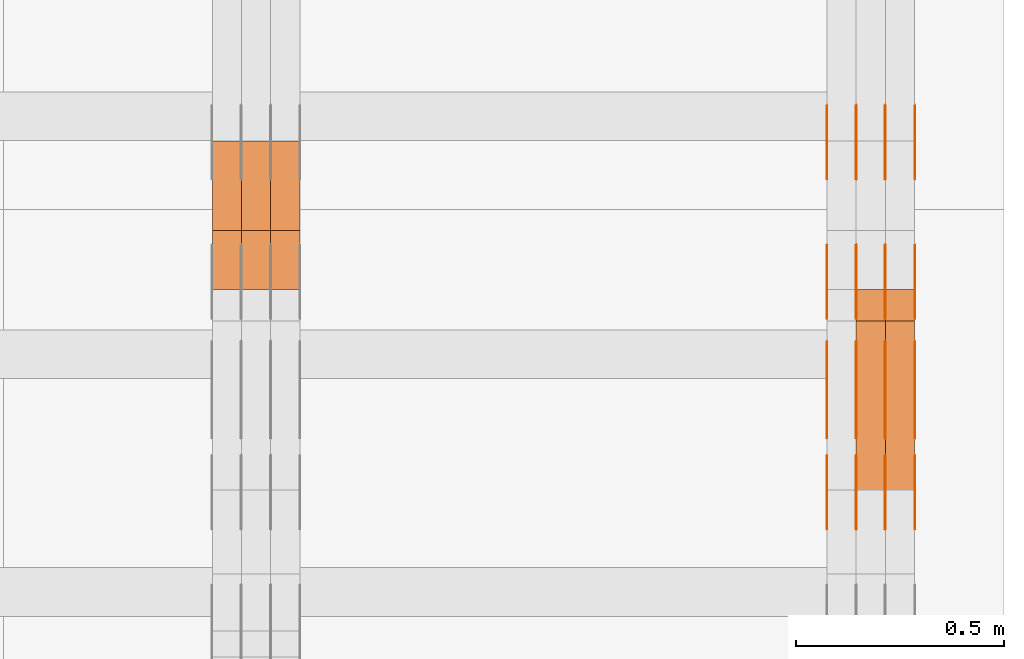
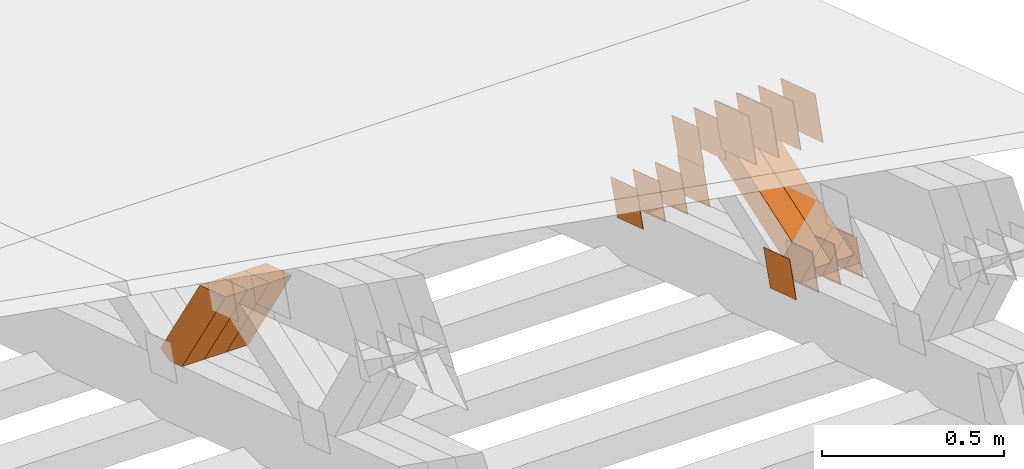
# One storey, part 367 of 385: 29 proxies.
"""IFC2X3 building model written with IfcOpenShell, lengths in millimetres."""

import ifcopenshell
import ifcopenshell.guid

model = None  # the IFC model being written
_history = None  # IfcOwnerHistory: only IFC2X3 demands one
_inside = {}  # id of a spatial element -> (the spatial element, [elements in it])
_under = {}  # id of a project, library or spatial element -> (it, [spatial elements below it])
_declared = {}  # id of a project -> (the project, [libraries it declares])
_typed = {}  # id of a type object -> (the type object, [elements of that type])
_made_of = {}  # id of a material, layer set ... -> (it, [elements and type objects made of it])


def new_model(schema):
    """Start an empty IFC model of exactly this schema.

    Asked for "IFC4X3", IfcOpenShell would pick the latest addendum, in which some entities
    have other attributes; the version numbers below select the first issue.
    IFC2X3 requires an IfcOwnerHistory on every rooted entity: one is made here for all.
    """
    global model, _history
    if schema == "IFC4X3":
        model = ifcopenshell.file(schema_version=(4, 3, 0, 0))
    else:
        model = ifcopenshell.file(schema=schema)
    _inside.clear()
    _under.clear()
    _declared.clear()
    _typed.clear()
    _made_of.clear()
    _history = None
    if model.schema == "IFC2X3":
        org = make("IfcOrganization", Name="unknown")
        user = make(
            "IfcPersonAndOrganization",
            ThePerson=make("IfcPerson", FamilyName="unknown"),
            TheOrganization=org,
        )
        app = make(
            "IfcApplication",
            ApplicationDeveloper=org,
            Version="unknown",
            ApplicationFullName="unknown",
            ApplicationIdentifier="unknown",
        )
        _history = make(
            "IfcOwnerHistory",
            OwningUser=user,
            OwningApplication=app,
            ChangeAction="ADDED",
            CreationDate=0,
        )
    return model


def make(cls, **values):
    """One entity of the class cls with the attributes given. An attribute that is None is left unset."""
    return model.create_entity(
        cls, **{name: value for name, value in values.items() if value is not None}
    )


def entity(cls, *values):
    """Any entity or typed value of the class cls, its attributes in the order of the schema. None: left unset."""
    e = model.create_entity(cls)
    for i, value in enumerate(values):
        if value is not None:
            e[i] = value
    return e


def rooted(cls, **values):
    """An entity with a GlobalId (a new one), such as an element, a storey or a relation."""
    return make(cls, GlobalId=ifcopenshell.guid.new(), OwnerHistory=_history, **values)


def si_unit(unit_type, name, prefix=None):
    """IfcSIUnit, for example si_unit("LENGTHUNIT", "METRE", prefix="MILLI")."""
    return make("IfcSIUnit", UnitType=unit_type, Prefix=prefix, Name=name)


def converted_unit(unit_type, name, factor, base, dimensions=None, offset=None):
    """IfcConversionBasedUnit, such as the inch: factor (a typed value) times the base unit."""
    return make(
        "IfcConversionBasedUnit"
        if offset is None
        else "IfcConversionBasedUnitWithOffset",
        ConversionOffset=offset,
        Dimensions=None
        if dimensions is None
        else entity("IfcDimensionalExponents", *dimensions),
        UnitType=unit_type,
        Name=name,
        ConversionFactor=make(
            "IfcMeasureWithUnit", ValueComponent=factor, UnitComponent=base
        ),
    )


def derived_unit(unit_type, elements):
    """IfcDerivedUnit: a product of units, each with its exponent."""
    return make(
        "IfcDerivedUnit",
        Elements=[
            make("IfcDerivedUnitElement", Unit=unit, Exponent=power)
            for unit, power in elements
        ],
        UnitType=unit_type,
    )


def assignment(units):
    """IfcUnitAssignment: the units of a project."""
    return None if units is None else make("IfcUnitAssignment", Units=units)


def point(xyz):
    """IfcCartesianPoint."""
    return None if xyz is None else make("IfcCartesianPoint", Coordinates=xyz)


def direction(xyz):
    """IfcDirection."""
    return None if xyz is None else make("IfcDirection", DirectionRatios=xyz)


def frame(location, z_axis=None, x_axis=None):
    """IfcAxis2Placement3D, a coordinate frame: its origin and axes. An axis left out is left unset."""
    return make(
        "IfcAxis2Placement3D",
        Location=point(location),
        Axis=direction(z_axis),
        RefDirection=direction(x_axis),
    )


def origin():
    """The frame at (0, 0, 0) with its axes left unset."""
    return frame((0.0, 0.0, 0.0))


def place(relative_to, where):
    """IfcLocalPlacement: puts the frame where relative to a parent placement (None: the world)."""
    return make(
        "IfcLocalPlacement", PlacementRelTo=relative_to, RelativePlacement=where
    )


def context(
    kind, dimensions, precision=None, world=None, true_north=None, identifier=None
):
    """IfcGeometricRepresentationContext, for example the 3D "Model" context."""
    return make(
        "IfcGeometricRepresentationContext",
        ContextIdentifier=identifier,
        ContextType=kind,
        CoordinateSpaceDimension=dimensions,
        Precision=precision,
        WorldCoordinateSystem=world,
        TrueNorth=true_north,
    )


def subcontext(parent, identifier, kind, view, scale=None):
    """IfcGeometricRepresentationSubContext, for example "Body" below "Model"."""
    return make(
        "IfcGeometricRepresentationSubContext",
        ContextIdentifier=identifier,
        ContextType=kind,
        ParentContext=parent,
        TargetScale=scale,
        TargetView=view,
    )


def project(units=None, contexts=None):
    """IfcProject with its units and contexts."""
    return rooted(
        "IfcProject",
        Name="project",
        RepresentationContexts=contexts,
        UnitsInContext=assignment(units),
    )


def spatial(cls, under=None, at=None, **own):
    """A site, building, storey or space (cls), placed at a placement, below another one or the project."""
    s = rooted(cls, ObjectPlacement=at, **own)
    if under is not None:
        _under.setdefault(under.id(), (under, []))[1].append(s)
    return s


def polyline(points):
    """IfcPolyline through the points."""
    return make("IfcPolyline", Points=[point(p) for p in points])


def outline(outer, holes=None, kind="AREA"):
    """IfcArbitraryClosedProfileDef: a profile drawn as a closed curve; with holes, ...WithVoids."""
    if holes is None:
        return make("IfcArbitraryClosedProfileDef", ProfileType=kind, OuterCurve=outer)
    return make(
        "IfcArbitraryProfileDefWithVoids",
        ProfileType=kind,
        OuterCurve=outer,
        InnerCurves=holes,
    )


def extrude(swept, where, along, depth):
    """IfcExtrudedAreaSolid: the profile swept, set in the frame where, extruded along a direction by depth."""
    return make(
        "IfcExtrudedAreaSolid",
        SweptArea=swept,
        Position=where,
        ExtrudedDirection=direction(along),
        Depth=depth,
    )


def shape(context_of_items, identifier, shape_type, items):
    """IfcShapeRepresentation: the items that make up one representation, for example the "Body"."""
    return make(
        "IfcShapeRepresentation",
        ContextOfItems=context_of_items,
        RepresentationIdentifier=identifier,
        RepresentationType=shape_type,
        Items=items,
    )


def source(mapping_origin, context_of_items, identifier, shape_type, items):
    """IfcRepresentationMap: a shape defined once, which mapped items show again and again."""
    return make(
        "IfcRepresentationMap",
        MappingOrigin=mapping_origin,
        MappedRepresentation=shape(context_of_items, identifier, shape_type, items),
    )


def transform(
    local_origin,
    x_axis=None,
    y_axis=None,
    z_axis=None,
    scale=None,
    scale2=None,
    scale3=None,
    uniform=True,
):
    """IfcCartesianTransformationOperator3D, or its non-uniform kind. x_axis, y_axis, z_axis: its Axis1, 2, 3."""
    if uniform:
        return make(
            "IfcCartesianTransformationOperator3D",
            Axis1=direction(x_axis),
            Axis2=direction(y_axis),
            LocalOrigin=point(local_origin),
            Scale=scale,
            Axis3=direction(z_axis),
        )
    return make(
        "IfcCartesianTransformationOperator3DnonUniform",
        Axis1=direction(x_axis),
        Axis2=direction(y_axis),
        LocalOrigin=point(local_origin),
        Scale=scale,
        Axis3=direction(z_axis),
        Scale2=scale2,
        Scale3=scale3,
    )


def mapped(mapping_source, mapping_target):
    """IfcMappedItem: shows the shape of a source again, moved by a transform."""
    return make(
        "IfcMappedItem", MappingSource=mapping_source, MappingTarget=mapping_target
    )


def material(Name=None, Category=None):
    """IfcMaterial."""
    return make("IfcMaterial", Name=Name, Category=Category)


def made_of(thing, what):
    """Note that an element or type object is made of a material, layer set ...; save() writes the relation."""
    if what is not None:
        _made_of.setdefault(what.id(), (what, []))[1].append(thing)
    return thing


def type_object(cls, material=None, **own):
    """A type object (cls), such as IfcWallType, which elements share."""
    return made_of(rooted(cls, **own), material)


def type_shapes(of_type, sources):
    """Give a type object the sources (RepresentationMaps) that its elements show as mapped items."""
    of_type.RepresentationMaps = sources


def element(
    cls,
    number,
    at=None,
    inside=None,
    cuts=None,
    type_object=None,
    material=None,
    context=None,
    identifier="Body",
    shape_type=None,
    held_by="IfcProductDefinitionShape",
    body=None,
    shapes=None,
    **own,
):
    """One element of the class cls, such as IfcWall. Its Tag is "e" and its number.

    at: its placement. inside: the storey or other place that contains it. cuts: it is an
    opening in that element (IfcRelVoidsElement). A single representation is given by context,
    identifier, shape_type and body (its items); several are given by shapes. held_by: the class
    of the entity that holds the representations. save() writes the other relations.
    """
    e = rooted(cls, Tag="e%d" % number, ObjectPlacement=at, **own)
    if body is not None:
        shapes = [shape(context, identifier, shape_type, body)]
    if shapes is not None:
        e.Representation = make(held_by, Representations=shapes)
    if inside is not None:
        _inside.setdefault(inside.id(), (inside, []))[1].append(e)
    if cuts is not None:
        rooted(
            "IfcRelVoidsElement", RelatingBuildingElement=cuts, RelatedOpeningElement=e
        )
    if type_object is not None:
        _typed.setdefault(type_object.id(), (type_object, []))[1].append(e)
    return made_of(e, material)


def aggregate(whole, parts):
    """IfcRelAggregates: a whole, such as a stair, and the parts it consists of."""
    return rooted("IfcRelAggregates", RelatingObject=whole, RelatedObjects=parts)


def save(model, path):
    """Write the relations noted so far, then the file.

    IfcRelAggregates (storeys below a building ...), IfcRelContainedInSpatialStructure (elements
    in a storey), IfcRelDefinesByType, IfcRelAssociatesMaterial and IfcRelDeclares: one each for
    every whole, place, type object, material and project.
    """
    for whole, parts in _under.values():
        aggregate(whole, parts)
    for where, things in _inside.values():
        rooted(
            "IfcRelContainedInSpatialStructure",
            RelatedElements=things,
            RelatingStructure=where,
        )
    for kind, things in _typed.values():
        rooted("IfcRelDefinesByType", RelatedObjects=things, RelatingType=kind)
    for what, things in _made_of.values():
        rooted("IfcRelAssociatesMaterial", RelatedObjects=things, RelatingMaterial=what)
    for by, libraries in _declared.values():
        rooted("IfcRelDeclares", RelatingContext=by, RelatedDefinitions=libraries)
    model.write(path)


model = new_model("IFC2X3")

# Units and contexts
model_context = context("Model", 3, precision=0.01, world=origin(), true_north=direction((6.12303176911189e-17, 1.0)))
body_context = subcontext(model_context, "Body", "Model", "MODEL_VIEW")
ifc_project = project(units=[si_unit("LENGTHUNIT", "METRE", prefix="MILLI"), si_unit("AREAUNIT", "SQUARE_METRE"), si_unit("VOLUMEUNIT", "CUBIC_METRE"), converted_unit("PLANEANGLEUNIT", "DEGREE", entity("IfcRatioMeasure", 0.0174532925199433), si_unit("PLANEANGLEUNIT", "RADIAN"), dimensions=[0, 0, 0, 0, 0, 0, 0]), si_unit("MASSUNIT", "GRAM", prefix="KILO"), derived_unit("MASSDENSITYUNIT", [(si_unit("MASSUNIT", "GRAM", prefix="KILO"), 1), (si_unit("LENGTHUNIT", "METRE"), -3)]), si_unit("TIMEUNIT", "SECOND"), si_unit("FREQUENCYUNIT", "HERTZ"), si_unit("THERMODYNAMICTEMPERATUREUNIT", "DEGREE_CELSIUS"), derived_unit("THERMALTRANSMITTANCEUNIT", [(si_unit("MASSUNIT", "GRAM", prefix="KILO"), 1), (si_unit("THERMODYNAMICTEMPERATUREUNIT", "KELVIN"), -1), (si_unit("TIMEUNIT", "SECOND"), -3)]), derived_unit("VOLUMETRICFLOWRATEUNIT", [(si_unit("LENGTHUNIT", "METRE"), 3), (si_unit("TIMEUNIT", "SECOND"), -1)]), si_unit("ELECTRICCURRENTUNIT", "AMPERE"), si_unit("ELECTRICVOLTAGEUNIT", "VOLT"), si_unit("POWERUNIT", "WATT"), si_unit("FORCEUNIT", "NEWTON", prefix="KILO"), si_unit("ILLUMINANCEUNIT", "LUX"), si_unit("LUMINOUSFLUXUNIT", "LUMEN"), si_unit("LUMINOUSINTENSITYUNIT", "CANDELA"), derived_unit("USERDEFINED", [(si_unit("MASSUNIT", "GRAM", prefix="KILO"), -1), (si_unit("LENGTHUNIT", "METRE"), -2), (si_unit("TIMEUNIT", "SECOND"), 3), (si_unit("LUMINOUSFLUXUNIT", "LUMEN"), 1)]), derived_unit("LINEARVELOCITYUNIT", [(si_unit("LENGTHUNIT", "METRE"), 1), (si_unit("TIMEUNIT", "SECOND"), -1)]), si_unit("PRESSUREUNIT", "PASCAL"), derived_unit("USERDEFINED", [(si_unit("LENGTHUNIT", "METRE"), -2), (si_unit("MASSUNIT", "GRAM", prefix="KILO"), 1), (si_unit("TIMEUNIT", "SECOND"), -2)])], contexts=[model_context])

# Site, building, storey
site_placement = place(None, origin())
site = spatial("IfcSite", under=ifc_project, at=site_placement, CompositionType="ELEMENT")
building_placement = place(site_placement, origin())
building = spatial("IfcBuilding", under=site, at=building_placement, CompositionType="ELEMENT")
storey_placement = place(building_placement, origin())
storey = spatial("IfcBuildingStorey", under=building, at=storey_placement, Name="Default", CompositionType="ELEMENT", Elevation=0.0)

# Proxies
ifc_material_1 = material(Name="IfcSurfaceStyle #625402")
building_element_proxy_type_1 = type_object("IfcBuildingElementProxyType", PredefinedType="NOTDEFINED", material=ifc_material_1)
shared_shape_1 = source(origin(), body_context, "Body", "SweptSolid", [
    extrude(outline(polyline([(-74.9998605591059, -59.9999264677526), (74.999875428623, -59.9999264677526), (74.9998605591068, 59.9999264677526), (-74.9998754286239, 59.9999264677526), (-74.9998605591059, -59.9999264677526)])), frame((75.0000889884782, 60.0000460315623, 0.0), z_axis=(0.0, 0.0, 1.0), x_axis=(-1.0, 0.0, 0.0)), (0.0, 0.0, 1.0), 1.3),
])
type_shapes(building_element_proxy_type_1, [shared_shape_1])
proxy_1_placement = place(building_placement, frame((49861.3, 20621.9679769682, 2241.76551219004), z_axis=(-1.0, 0.0, 0.0), x_axis=(0.0, -0.951056516295154, 0.309016994374948)))
element("IfcBuildingElementProxy", 1, at=proxy_1_placement, inside=storey, type_object=building_element_proxy_type_1, material=ifc_material_1, context=body_context, shape_type="MappedRepresentation", body=[
    mapped(shared_shape_1, transform((0.0, 0.0, 0.0), scale=1.0)),
])
ifc_material_2 = material(Name="IfcSurfaceStyle #625345")
building_element_proxy_type_2 = type_object("IfcBuildingElementProxyType", PredefinedType="NOTDEFINED", material=ifc_material_2)
shared_shape_2 = source(origin(), body_context, "Body", "SweptSolid", [
    extrude(outline(polyline([(-74.9998605591059, -59.9999264677526), (74.999875428623, -59.9999264677526), (74.9998605591068, 59.9999264677526), (-74.9998754286239, 59.9999264677526), (-74.9998605591059, -59.9999264677526)])), frame((75.0000889884782, 60.0000460315623, 0.0), z_axis=(0.0, 0.0, 1.0), x_axis=(-1.0, 0.0, 0.0)), (0.0, 0.0, 1.0), 1.3),
])
type_shapes(building_element_proxy_type_2, [shared_shape_2])
proxy_2_placement = place(building_placement, frame((49790.0, 20621.9679769682, 2241.76551219004), z_axis=(-1.0, 0.0, 0.0), x_axis=(0.0, -0.951056516295154, 0.309016994374948)))
element("IfcBuildingElementProxy", 2, at=proxy_2_placement, inside=storey, type_object=building_element_proxy_type_2, material=ifc_material_2, context=body_context, shape_type="MappedRepresentation", body=[
    mapped(shared_shape_2, transform((0.0, 0.0, 0.0), scale=1.0)),
])
ifc_material_3 = material(Name="IfcSurfaceStyle #625288")
building_element_proxy_type_3 = type_object("IfcBuildingElementProxyType", PredefinedType="NOTDEFINED", material=ifc_material_3)
shared_shape_3 = source(origin(), body_context, "Body", "SweptSolid", [
    extrude(outline(polyline([(-74.9998605591059, -59.9999264677526), (74.999875428623, -59.9999264677526), (74.9998605591068, 59.9999264677526), (-74.9998754286239, 59.9999264677526), (-74.9998605591059, -59.9999264677526)])), frame((75.0000889884782, 60.0000460315623, 0.0), z_axis=(0.0, 0.0, 1.0), x_axis=(-1.0, 0.0, 0.0)), (0.0, 0.0, 1.0), 1.3),
])
type_shapes(building_element_proxy_type_3, [shared_shape_3])
proxy_3_placement = place(building_placement, frame((49791.3, 20621.9679769682, 2241.76551219004), z_axis=(-1.0, 0.0, 0.0), x_axis=(0.0, -0.951056516295154, 0.309016994374948)))
element("IfcBuildingElementProxy", 3, at=proxy_3_placement, inside=storey, type_object=building_element_proxy_type_3, material=ifc_material_3, context=body_context, shape_type="MappedRepresentation", body=[
    mapped(shared_shape_3, transform((0.0, 0.0, 0.0), scale=1.0)),
])
ifc_material_4 = material(Name="IfcSurfaceStyle #625231")
building_element_proxy_type_4 = type_object("IfcBuildingElementProxyType", PredefinedType="NOTDEFINED", material=ifc_material_4)
shared_shape_4 = source(origin(), body_context, "Body", "SweptSolid", [
    extrude(outline(polyline([(-74.9998605591059, -59.9999264677526), (74.999875428623, -59.9999264677526), (74.9998605591068, 59.9999264677526), (-74.9998754286239, 59.9999264677526), (-74.9998605591059, -59.9999264677526)])), frame((75.0000889884782, 60.0000460315623, 0.0), z_axis=(0.0, 0.0, 1.0), x_axis=(-1.0, 0.0, 0.0)), (0.0, 0.0, 1.0), 1.29999999999999),
])
type_shapes(building_element_proxy_type_4, [shared_shape_4])
proxy_4_placement = place(building_placement, frame((49720.0, 20621.9679769682, 2241.76551219004), z_axis=(-1.0, 0.0, 0.0), x_axis=(0.0, -0.951056516295154, 0.309016994374948)))
element("IfcBuildingElementProxy", 4, at=proxy_4_placement, inside=storey, type_object=building_element_proxy_type_4, material=ifc_material_4, context=body_context, shape_type="MappedRepresentation", body=[
    mapped(shared_shape_4, transform((0.0, 0.0, 0.0), scale=1.0)),
])
ifc_material_5 = material(Name="IfcSurfaceStyle #625174")
building_element_proxy_type_5 = type_object("IfcBuildingElementProxyType", PredefinedType="NOTDEFINED", material=ifc_material_5)
shared_shape_5 = source(origin(), body_context, "Body", "SweptSolid", [
    extrude(outline(polyline([(-74.9998605591059, -59.9999264677526), (74.999875428623, -59.9999264677526), (74.9998605591068, 59.9999264677526), (-74.9998754286239, 59.9999264677526), (-74.9998605591059, -59.9999264677526)])), frame((75.0000889884782, 60.0000460315623, 0.0), z_axis=(0.0, 0.0, 1.0), x_axis=(-1.0, 0.0, 0.0)), (0.0, 0.0, 1.0), 1.29999999999999),
])
type_shapes(building_element_proxy_type_5, [shared_shape_5])
proxy_5_placement = place(building_placement, frame((49721.3, 20621.9679769682, 2241.76551219004), z_axis=(-1.0, 0.0, 0.0), x_axis=(0.0, -0.951056516295154, 0.309016994374948)))
element("IfcBuildingElementProxy", 5, at=proxy_5_placement, inside=storey, type_object=building_element_proxy_type_5, material=ifc_material_5, context=body_context, shape_type="MappedRepresentation", body=[
    mapped(shared_shape_5, transform((0.0, 0.0, 0.0), scale=1.0)),
])
ifc_material_6 = material(Name="IfcSurfaceStyle #625117")
building_element_proxy_type_6 = type_object("IfcBuildingElementProxyType", PredefinedType="NOTDEFINED", material=ifc_material_6)
shared_shape_6 = source(origin(), body_context, "Body", "SweptSolid", [
    extrude(outline(polyline([(-74.9998605591059, -59.9999264677526), (74.999875428623, -59.9999264677526), (74.9998605591068, 59.9999264677526), (-74.9998754286239, 59.9999264677526), (-74.9998605591059, -59.9999264677526)])), frame((75.0000889884782, 60.0000460315623, 0.0), z_axis=(0.0, 0.0, 1.0), x_axis=(-1.0, 0.0, 0.0)), (0.0, 0.0, 1.0), 1.29999999999999),
])
type_shapes(building_element_proxy_type_6, [shared_shape_6])
proxy_6_placement = place(building_placement, frame((49650.0, 20621.9679769682, 2241.76551219004), z_axis=(-1.0, 0.0, 0.0), x_axis=(0.0, -0.951056516295154, 0.309016994374948)))
element("IfcBuildingElementProxy", 6, at=proxy_6_placement, inside=storey, type_object=building_element_proxy_type_6, material=ifc_material_6, context=body_context, shape_type="MappedRepresentation", body=[
    mapped(shared_shape_6, transform((0.0, 0.0, 0.0), scale=1.0)),
])
ifc_material_7 = material(Name="IfcSurfaceStyle #623692")
building_element_proxy_type_7 = type_object("IfcBuildingElementProxyType", PredefinedType="NOTDEFINED", material=ifc_material_7)
shared_shape_7 = source(origin(), body_context, "Body", "SweptSolid", [
    extrude(outline(polyline([(-100.000260677523, -72.0000050220369), (100.000341220114, -72.0000050220369), (99.9997962944585, 72.0000050220369), (-99.9998768370492, 72.0000050220369), (-100.000260677523, -72.0000050220369)])), frame((100.000341220114, 72.0001826453454, 0.0), z_axis=(0.0, 0.0, 1.0), x_axis=(-1.0, 0.0, 0.0)), (0.0, 0.0, 1.0), 1.3),
])
type_shapes(building_element_proxy_type_7, [shared_shape_7])
proxy_7_placement = place(building_placement, frame((49861.3, 20382.8706354426, 2409.35285895246), z_axis=(-1.0, 0.0, 0.0), x_axis=(0.0, -0.951056516295154, 0.309016994374948)))
element("IfcBuildingElementProxy", 7, at=proxy_7_placement, inside=storey, type_object=building_element_proxy_type_7, material=ifc_material_7, context=body_context, shape_type="MappedRepresentation", body=[
    mapped(shared_shape_7, transform((0.0, 0.0, 0.0), scale=1.0)),
])
ifc_material_8 = material(Name="IfcSurfaceStyle #623635")
building_element_proxy_type_8 = type_object("IfcBuildingElementProxyType", PredefinedType="NOTDEFINED", material=ifc_material_8)
shared_shape_8 = source(origin(), body_context, "Body", "SweptSolid", [
    extrude(outline(polyline([(-100.000260677523, -72.0000050220369), (100.000341220114, -72.0000050220369), (99.9997962944585, 72.0000050220369), (-99.9998768370492, 72.0000050220369), (-100.000260677523, -72.0000050220369)])), frame((100.000341220114, 72.0001826453454, 0.0), z_axis=(0.0, 0.0, 1.0), x_axis=(-1.0, 0.0, 0.0)), (0.0, 0.0, 1.0), 1.3),
])
type_shapes(building_element_proxy_type_8, [shared_shape_8])
proxy_8_placement = place(building_placement, frame((49790.0, 20382.8706354426, 2409.35285895246), z_axis=(-1.0, 0.0, 0.0), x_axis=(0.0, -0.951056516295154, 0.309016994374948)))
element("IfcBuildingElementProxy", 8, at=proxy_8_placement, inside=storey, type_object=building_element_proxy_type_8, material=ifc_material_8, context=body_context, shape_type="MappedRepresentation", body=[
    mapped(shared_shape_8, transform((0.0, 0.0, 0.0), scale=1.0)),
])
ifc_material_9 = material(Name="IfcSurfaceStyle #623578")
building_element_proxy_type_9 = type_object("IfcBuildingElementProxyType", PredefinedType="NOTDEFINED", material=ifc_material_9)
shared_shape_9 = source(origin(), body_context, "Body", "SweptSolid", [
    extrude(outline(polyline([(-100.000260677523, -72.0000050220369), (100.000341220114, -72.0000050220369), (99.9997962944585, 72.0000050220369), (-99.9998768370492, 72.0000050220369), (-100.000260677523, -72.0000050220369)])), frame((100.000341220114, 72.0001826453454, 0.0), z_axis=(0.0, 0.0, 1.0), x_axis=(-1.0, 0.0, 0.0)), (0.0, 0.0, 1.0), 1.3),
])
type_shapes(building_element_proxy_type_9, [shared_shape_9])
proxy_9_placement = place(building_placement, frame((49791.3, 20382.8706354426, 2409.35285895246), z_axis=(-1.0, 0.0, 0.0), x_axis=(0.0, -0.951056516295154, 0.309016994374948)))
element("IfcBuildingElementProxy", 9, at=proxy_9_placement, inside=storey, type_object=building_element_proxy_type_9, material=ifc_material_9, context=body_context, shape_type="MappedRepresentation", body=[
    mapped(shared_shape_9, transform((0.0, 0.0, 0.0), scale=1.0)),
])
ifc_material_10 = material(Name="IfcSurfaceStyle #623521")
building_element_proxy_type_10 = type_object("IfcBuildingElementProxyType", PredefinedType="NOTDEFINED", material=ifc_material_10)
shared_shape_10 = source(origin(), body_context, "Body", "SweptSolid", [
    extrude(outline(polyline([(-100.000260677523, -72.0000050220369), (100.000341220114, -72.0000050220369), (99.9997962944585, 72.0000050220369), (-99.9998768370492, 72.0000050220369), (-100.000260677523, -72.0000050220369)])), frame((100.000341220114, 72.0001826453454, 0.0), z_axis=(0.0, 0.0, 1.0), x_axis=(-1.0, 0.0, 0.0)), (0.0, 0.0, 1.0), 1.29999999999998),
])
type_shapes(building_element_proxy_type_10, [shared_shape_10])
proxy_10_placement = place(building_placement, frame((49720.0, 20382.8706354426, 2409.35285895246), z_axis=(-1.0, 0.0, 0.0), x_axis=(0.0, -0.951056516295154, 0.309016994374948)))
element("IfcBuildingElementProxy", 10, at=proxy_10_placement, inside=storey, type_object=building_element_proxy_type_10, material=ifc_material_10, context=body_context, shape_type="MappedRepresentation", body=[
    mapped(shared_shape_10, transform((0.0, 0.0, 0.0), scale=1.0)),
])
ifc_material_11 = material(Name="IfcSurfaceStyle #623464")
building_element_proxy_type_11 = type_object("IfcBuildingElementProxyType", PredefinedType="NOTDEFINED", material=ifc_material_11)
shared_shape_11 = source(origin(), body_context, "Body", "SweptSolid", [
    extrude(outline(polyline([(-100.000260677523, -72.0000050220369), (100.000341220114, -72.0000050220369), (99.9997962944585, 72.0000050220369), (-99.9998768370492, 72.0000050220369), (-100.000260677523, -72.0000050220369)])), frame((100.000341220114, 72.0001826453454, 0.0), z_axis=(0.0, 0.0, 1.0), x_axis=(-1.0, 0.0, 0.0)), (0.0, 0.0, 1.0), 1.29999999999998),
])
type_shapes(building_element_proxy_type_11, [shared_shape_11])
proxy_11_placement = place(building_placement, frame((49721.3, 20382.8706354426, 2409.35285895246), z_axis=(-1.0, 0.0, 0.0), x_axis=(0.0, -0.951056516295154, 0.309016994374948)))
element("IfcBuildingElementProxy", 11, at=proxy_11_placement, inside=storey, type_object=building_element_proxy_type_11, material=ifc_material_11, context=body_context, shape_type="MappedRepresentation", body=[
    mapped(shared_shape_11, transform((0.0, 0.0, 0.0), scale=1.0)),
])
ifc_material_12 = material(Name="IfcSurfaceStyle #623407")
building_element_proxy_type_12 = type_object("IfcBuildingElementProxyType", PredefinedType="NOTDEFINED", material=ifc_material_12)
shared_shape_12 = source(origin(), body_context, "Body", "SweptSolid", [
    extrude(outline(polyline([(-100.000260677523, -72.0000050220369), (100.000341220114, -72.0000050220369), (99.9997962944585, 72.0000050220369), (-99.9998768370492, 72.0000050220369), (-100.000260677523, -72.0000050220369)])), frame((100.000341220114, 72.0001826453454, 0.0), z_axis=(0.0, 0.0, 1.0), x_axis=(-1.0, 0.0, 0.0)), (0.0, 0.0, 1.0), 1.29999999999999),
])
type_shapes(building_element_proxy_type_12, [shared_shape_12])
proxy_12_placement = place(building_placement, frame((49650.0, 20382.8706354426, 2409.35285895246), z_axis=(-1.0, 0.0, 0.0), x_axis=(0.0, -0.951056516295154, 0.309016994374948)))
element("IfcBuildingElementProxy", 12, at=proxy_12_placement, inside=storey, type_object=building_element_proxy_type_12, material=ifc_material_12, context=body_context, shape_type="MappedRepresentation", body=[
    mapped(shared_shape_12, transform((0.0, 0.0, 0.0), scale=1.0)),
])
ifc_material_13 = material(Name="IfcSurfaceStyle #617194")
building_element_proxy_type_13 = type_object("IfcBuildingElementProxyType", PredefinedType="NOTDEFINED", material=ifc_material_13)
shared_shape_13 = source(origin(), body_context, "Body", "SweptSolid", [
    extrude(outline(polyline([(-74.9998605591118, -59.9999264677598), (74.9998754286171, -59.9999264677598), (74.9998605591136, 59.9999264677598), (-74.9998754286189, 59.9999264677598), (-74.9998605591118, -59.9999264677598)])), frame((75.0000347664736, 60.0000016373434, 0.0), z_axis=(0.0, 0.0, 1.0), x_axis=(-1.0, 0.0, 0.0)), (0.0, 0.0, 1.0), 1.3),
])
type_shapes(building_element_proxy_type_13, [shared_shape_13])
proxy_13_placement = place(building_placement, frame((49861.3, 20117.0890328685, 2105.40814929196), z_axis=(-1.0, 0.0, 0.0), x_axis=(0.0, -0.951056516295124, 0.309016994375039)))
element("IfcBuildingElementProxy", 13, at=proxy_13_placement, inside=storey, type_object=building_element_proxy_type_13, material=ifc_material_13, context=body_context, shape_type="MappedRepresentation", body=[
    mapped(shared_shape_13, transform((0.0, 0.0, 0.0), scale=1.0)),
])
ifc_material_14 = material(Name="IfcSurfaceStyle #617137")
building_element_proxy_type_14 = type_object("IfcBuildingElementProxyType", PredefinedType="NOTDEFINED", material=ifc_material_14)
shared_shape_14 = source(origin(), body_context, "Body", "SweptSolid", [
    extrude(outline(polyline([(-74.9998605591118, -59.9999264677598), (74.9998754286171, -59.9999264677598), (74.9998605591136, 59.9999264677598), (-74.9998754286189, 59.9999264677598), (-74.9998605591118, -59.9999264677598)])), frame((75.0000347664736, 60.0000016373434, 0.0), z_axis=(0.0, 0.0, 1.0), x_axis=(-1.0, 0.0, 0.0)), (0.0, 0.0, 1.0), 1.3),
])
type_shapes(building_element_proxy_type_14, [shared_shape_14])
proxy_14_placement = place(building_placement, frame((49790.0, 20117.0890328685, 2105.40814929196), z_axis=(-1.0, 0.0, 0.0), x_axis=(0.0, -0.951056516295124, 0.309016994375039)))
element("IfcBuildingElementProxy", 14, at=proxy_14_placement, inside=storey, type_object=building_element_proxy_type_14, material=ifc_material_14, context=body_context, shape_type="MappedRepresentation", body=[
    mapped(shared_shape_14, transform((0.0, 0.0, 0.0), scale=1.0)),
])
ifc_material_15 = material(Name="IfcSurfaceStyle #617080")
building_element_proxy_type_15 = type_object("IfcBuildingElementProxyType", PredefinedType="NOTDEFINED", material=ifc_material_15)
shared_shape_15 = source(origin(), body_context, "Body", "SweptSolid", [
    extrude(outline(polyline([(-74.9998605591118, -59.9999264677598), (74.9998754286171, -59.9999264677598), (74.9998605591136, 59.9999264677598), (-74.9998754286189, 59.9999264677598), (-74.9998605591118, -59.9999264677598)])), frame((75.0000347664736, 60.0000016373434, 0.0), z_axis=(0.0, 0.0, 1.0), x_axis=(-1.0, 0.0, 0.0)), (0.0, 0.0, 1.0), 1.3),
])
type_shapes(building_element_proxy_type_15, [shared_shape_15])
proxy_15_placement = place(building_placement, frame((49791.3, 20117.0890328685, 2105.40814929196), z_axis=(-1.0, 0.0, 0.0), x_axis=(0.0, -0.951056516295124, 0.309016994375039)))
element("IfcBuildingElementProxy", 15, at=proxy_15_placement, inside=storey, type_object=building_element_proxy_type_15, material=ifc_material_15, context=body_context, shape_type="MappedRepresentation", body=[
    mapped(shared_shape_15, transform((0.0, 0.0, 0.0), scale=1.0)),
])
ifc_material_16 = material(Name="IfcSurfaceStyle #617023")
building_element_proxy_type_16 = type_object("IfcBuildingElementProxyType", PredefinedType="NOTDEFINED", material=ifc_material_16)
shared_shape_16 = source(origin(), body_context, "Body", "SweptSolid", [
    extrude(outline(polyline([(-74.9998605591118, -59.9999264677598), (74.9998754286171, -59.9999264677598), (74.9998605591136, 59.9999264677598), (-74.9998754286189, 59.9999264677598), (-74.9998605591118, -59.9999264677598)])), frame((75.0000347664736, 60.0000016373434, 0.0), z_axis=(0.0, 0.0, 1.0), x_axis=(-1.0, 0.0, 0.0)), (0.0, 0.0, 1.0), 1.29999999999999),
])
type_shapes(building_element_proxy_type_16, [shared_shape_16])
proxy_16_placement = place(building_placement, frame((49720.0, 20117.0890328685, 2105.40814929196), z_axis=(-1.0, 0.0, 0.0), x_axis=(0.0, -0.951056516295124, 0.309016994375039)))
element("IfcBuildingElementProxy", 16, at=proxy_16_placement, inside=storey, type_object=building_element_proxy_type_16, material=ifc_material_16, context=body_context, shape_type="MappedRepresentation", body=[
    mapped(shared_shape_16, transform((0.0, 0.0, 0.0), scale=1.0)),
])
ifc_material_17 = material(Name="IfcSurfaceStyle #616966")
building_element_proxy_type_17 = type_object("IfcBuildingElementProxyType", PredefinedType="NOTDEFINED", material=ifc_material_17)
shared_shape_17 = source(origin(), body_context, "Body", "SweptSolid", [
    extrude(outline(polyline([(-74.9998605591118, -59.9999264677598), (74.9998754286171, -59.9999264677598), (74.9998605591136, 59.9999264677598), (-74.9998754286189, 59.9999264677598), (-74.9998605591118, -59.9999264677598)])), frame((75.0000347664736, 60.0000016373434, 0.0), z_axis=(0.0, 0.0, 1.0), x_axis=(-1.0, 0.0, 0.0)), (0.0, 0.0, 1.0), 1.29999999999999),
])
type_shapes(building_element_proxy_type_17, [shared_shape_17])
proxy_17_placement = place(building_placement, frame((49721.3, 20117.0890328685, 2105.40814929196), z_axis=(-1.0, 0.0, 0.0), x_axis=(0.0, -0.951056516295124, 0.309016994375039)))
element("IfcBuildingElementProxy", 17, at=proxy_17_placement, inside=storey, type_object=building_element_proxy_type_17, material=ifc_material_17, context=body_context, shape_type="MappedRepresentation", body=[
    mapped(shared_shape_17, transform((0.0, 0.0, 0.0), scale=1.0)),
])
ifc_material_18 = material(Name="IfcSurfaceStyle #616909")
building_element_proxy_type_18 = type_object("IfcBuildingElementProxyType", PredefinedType="NOTDEFINED", material=ifc_material_18)
shared_shape_18 = source(origin(), body_context, "Body", "SweptSolid", [
    extrude(outline(polyline([(-74.9998605591118, -59.9999264677598), (74.9998754286171, -59.9999264677598), (74.9998605591136, 59.9999264677598), (-74.9998754286189, 59.9999264677598), (-74.9998605591118, -59.9999264677598)])), frame((75.0000347664736, 60.0000016373434, 0.0), z_axis=(0.0, 0.0, 1.0), x_axis=(-1.0, 0.0, 0.0)), (0.0, 0.0, 1.0), 1.29999999999999),
])
type_shapes(building_element_proxy_type_18, [shared_shape_18])
proxy_18_placement = place(building_placement, frame((49650.0, 20117.0890328685, 2105.40814929196), z_axis=(-1.0, 0.0, 0.0), x_axis=(0.0, -0.951056516295124, 0.309016994375039)))
element("IfcBuildingElementProxy", 18, at=proxy_18_placement, inside=storey, type_object=building_element_proxy_type_18, material=ifc_material_18, context=body_context, shape_type="MappedRepresentation", body=[
    mapped(shared_shape_18, transform((0.0, 0.0, 0.0), scale=1.0)),
])
ifc_material_19 = material(Name="IfcSurfaceStyle #616852")
building_element_proxy_type_19 = type_object("IfcBuildingElementProxyType", PredefinedType="NOTDEFINED", material=ifc_material_19)
shared_shape_19 = source(origin(), body_context, "Body", "SweptSolid", [
    extrude(outline(polyline([(-74.9998794200132, -59.999984515643), (74.9998565677174, -59.999984515643), (74.9998794200123, 59.999984515643), (-74.9998565677165, 59.999984515643), (-74.9998794200132, -59.999984515643)])), frame((75.0002235343086, 60.0000596852268, 0.0), z_axis=(0.0, 0.0, 1.0), x_axis=(-1.0, 0.0, 0.0)), (0.0, 0.0, 1.0), 1.3),
])
type_shapes(building_element_proxy_type_19, [shared_shape_19])
proxy_19_placement = place(building_placement, frame((49861.3, 20956.2317725846, 1832.75404405346), z_axis=(-1.0, 0.0, 0.0), x_axis=(0.0, -0.951056516295124, 0.309016994375039)))
element("IfcBuildingElementProxy", 19, at=proxy_19_placement, inside=storey, type_object=building_element_proxy_type_19, material=ifc_material_19, context=body_context, shape_type="MappedRepresentation", body=[
    mapped(shared_shape_19, transform((0.0, 0.0, 0.0), scale=1.0)),
])
ifc_material_20 = material(Name="IfcSurfaceStyle #616795")
building_element_proxy_type_20 = type_object("IfcBuildingElementProxyType", PredefinedType="NOTDEFINED", material=ifc_material_20)
shared_shape_20 = source(origin(), body_context, "Body", "SweptSolid", [
    extrude(outline(polyline([(-74.9998794200132, -59.999984515643), (74.9998565677174, -59.999984515643), (74.9998794200123, 59.999984515643), (-74.9998565677165, 59.999984515643), (-74.9998794200132, -59.999984515643)])), frame((75.0002235343086, 60.0000596852268, 0.0), z_axis=(0.0, 0.0, 1.0), x_axis=(-1.0, 0.0, 0.0)), (0.0, 0.0, 1.0), 1.3),
])
type_shapes(building_element_proxy_type_20, [shared_shape_20])
proxy_20_placement = place(building_placement, frame((49790.0, 20956.2317725846, 1832.75404405346), z_axis=(-1.0, 0.0, 0.0), x_axis=(0.0, -0.951056516295124, 0.309016994375039)))
element("IfcBuildingElementProxy", 20, at=proxy_20_placement, inside=storey, type_object=building_element_proxy_type_20, material=ifc_material_20, context=body_context, shape_type="MappedRepresentation", body=[
    mapped(shared_shape_20, transform((0.0, 0.0, 0.0), scale=1.0)),
])
ifc_material_21 = material(Name="IfcSurfaceStyle #616738")
building_element_proxy_type_21 = type_object("IfcBuildingElementProxyType", PredefinedType="NOTDEFINED", material=ifc_material_21)
shared_shape_21 = source(origin(), body_context, "Body", "SweptSolid", [
    extrude(outline(polyline([(-74.9998794200132, -59.999984515643), (74.9998565677174, -59.999984515643), (74.9998794200123, 59.999984515643), (-74.9998565677165, 59.999984515643), (-74.9998794200132, -59.999984515643)])), frame((75.0002235343086, 60.0000596852268, 0.0), z_axis=(0.0, 0.0, 1.0), x_axis=(-1.0, 0.0, 0.0)), (0.0, 0.0, 1.0), 1.3),
])
type_shapes(building_element_proxy_type_21, [shared_shape_21])
proxy_21_placement = place(building_placement, frame((49791.3, 20956.2317725846, 1832.75404405346), z_axis=(-1.0, 0.0, 0.0), x_axis=(0.0, -0.951056516295124, 0.309016994375039)))
element("IfcBuildingElementProxy", 21, at=proxy_21_placement, inside=storey, type_object=building_element_proxy_type_21, material=ifc_material_21, context=body_context, shape_type="MappedRepresentation", body=[
    mapped(shared_shape_21, transform((0.0, 0.0, 0.0), scale=1.0)),
])
ifc_material_22 = material(Name="IfcSurfaceStyle #616681")
building_element_proxy_type_22 = type_object("IfcBuildingElementProxyType", PredefinedType="NOTDEFINED", material=ifc_material_22)
shared_shape_22 = source(origin(), body_context, "Body", "SweptSolid", [
    extrude(outline(polyline([(-74.9998794200132, -59.999984515643), (74.9998565677174, -59.999984515643), (74.9998794200123, 59.999984515643), (-74.9998565677165, 59.999984515643), (-74.9998794200132, -59.999984515643)])), frame((75.0002235343086, 60.0000596852268, 0.0), z_axis=(0.0, 0.0, 1.0), x_axis=(-1.0, 0.0, 0.0)), (0.0, 0.0, 1.0), 1.29999999999999),
])
type_shapes(building_element_proxy_type_22, [shared_shape_22])
proxy_22_placement = place(building_placement, frame((49720.0, 20956.2317725846, 1832.75404405346), z_axis=(-1.0, 0.0, 0.0), x_axis=(0.0, -0.951056516295124, 0.309016994375039)))
element("IfcBuildingElementProxy", 22, at=proxy_22_placement, inside=storey, type_object=building_element_proxy_type_22, material=ifc_material_22, context=body_context, shape_type="MappedRepresentation", body=[
    mapped(shared_shape_22, transform((0.0, 0.0, 0.0), scale=1.0)),
])
ifc_material_23 = material(Name="IfcSurfaceStyle #616624")
building_element_proxy_type_23 = type_object("IfcBuildingElementProxyType", PredefinedType="NOTDEFINED", material=ifc_material_23)
shared_shape_23 = source(origin(), body_context, "Body", "SweptSolid", [
    extrude(outline(polyline([(-74.9998794200132, -59.999984515643), (74.9998565677174, -59.999984515643), (74.9998794200123, 59.999984515643), (-74.9998565677165, 59.999984515643), (-74.9998794200132, -59.999984515643)])), frame((75.0002235343086, 60.0000596852268, 0.0), z_axis=(0.0, 0.0, 1.0), x_axis=(-1.0, 0.0, 0.0)), (0.0, 0.0, 1.0), 1.29999999999999),
])
type_shapes(building_element_proxy_type_23, [shared_shape_23])
proxy_23_placement = place(building_placement, frame((49721.3, 20956.2317725846, 1832.75404405346), z_axis=(-1.0, 0.0, 0.0), x_axis=(0.0, -0.951056516295124, 0.309016994375039)))
element("IfcBuildingElementProxy", 23, at=proxy_23_placement, inside=storey, type_object=building_element_proxy_type_23, material=ifc_material_23, context=body_context, shape_type="MappedRepresentation", body=[
    mapped(shared_shape_23, transform((0.0, 0.0, 0.0), scale=1.0)),
])
ifc_material_24 = material(Name="IfcSurfaceStyle #616567")
building_element_proxy_type_24 = type_object("IfcBuildingElementProxyType", PredefinedType="NOTDEFINED", material=ifc_material_24)
shared_shape_24 = source(origin(), body_context, "Body", "SweptSolid", [
    extrude(outline(polyline([(-74.9998794200132, -59.999984515643), (74.9998565677174, -59.999984515643), (74.9998794200123, 59.999984515643), (-74.9998565677165, 59.999984515643), (-74.9998794200132, -59.999984515643)])), frame((75.0002235343086, 60.0000596852268, 0.0), z_axis=(0.0, 0.0, 1.0), x_axis=(-1.0, 0.0, 0.0)), (0.0, 0.0, 1.0), 1.29999999999999),
])
type_shapes(building_element_proxy_type_24, [shared_shape_24])
proxy_24_placement = place(building_placement, frame((49650.0, 20956.2317725846, 1832.75404405346), z_axis=(-1.0, 0.0, 0.0), x_axis=(0.0, -0.951056516295124, 0.309016994375039)))
element("IfcBuildingElementProxy", 24, at=proxy_24_placement, inside=storey, type_object=building_element_proxy_type_24, material=ifc_material_24, context=body_context, shape_type="MappedRepresentation", body=[
    mapped(shared_shape_24, transform((0.0, 0.0, 0.0), scale=1.0)),
])
ifc_material_25 = material(Name="IfcSurfaceStyle #599590")
building_element_proxy_type_25 = type_object("IfcBuildingElementProxyType", Name="T2-W26 599588", PredefinedType="NOTDEFINED", material=ifc_material_25)
shared_shape_25 = source(origin(), body_context, "Body", "SweptSolid", [
    extrude(outline(polyline([(-339.390941716546, -47.5001331548025), (137.738864791781, -47.5001331548025), (201.272298560955, 6.02772073885038e-05), (212.703852542003, 47.5001030161988), (-212.324074178193, 47.5001030161988), (-339.390941716546, -47.5001331548025)])), frame((212.703852542003, 47.5001030161988, 0.0), z_axis=(0.0, 0.0, 1.0), x_axis=(-1.0, 0.0, 0.0)), (0.0, 0.0, 1.0), 70.0),
])
type_shapes(building_element_proxy_type_25, [shared_shape_25])
proxy_25_placement = place(building_placement, frame((49860.0, 20576.541015625, 2286.80981445313), z_axis=(-1.0, 0.0, 0.0), x_axis=(0.0, -0.946743816465327, -0.321987804093053)))
element("IfcBuildingElementProxy", 25, at=proxy_25_placement, inside=storey, type_object=building_element_proxy_type_25, material=ifc_material_25, Name="T2-W26", context=body_context, shape_type="MappedRepresentation", body=[
    mapped(shared_shape_25, transform((0.0, 0.0, 0.0), scale=1.0)),
])
ifc_material_26 = material(Name="IfcSurfaceStyle #599524")
building_element_proxy_type_26 = type_object("IfcBuildingElementProxyType", Name="T2-W26 599522", PredefinedType="NOTDEFINED", material=ifc_material_26)
shared_shape_26 = source(origin(), body_context, "Body", "SweptSolid", [
    extrude(outline(polyline([(-339.390941716546, -47.5001331548025), (137.738864791781, -47.5001331548025), (201.272298560955, 6.02772073885038e-05), (212.703852542003, 47.5001030161988), (-212.324074178193, 47.5001030161988), (-339.390941716546, -47.5001331548025)])), frame((212.703852542003, 47.5001030161988, 0.0), z_axis=(0.0, 0.0, 1.0), x_axis=(-1.0, 0.0, 0.0)), (0.0, 0.0, 1.0), 70.0),
])
type_shapes(building_element_proxy_type_26, [shared_shape_26])
proxy_26_placement = place(building_placement, frame((49790.0, 20576.541015625, 2286.80981445313), z_axis=(-1.0, 0.0, 0.0), x_axis=(0.0, -0.946743816465327, -0.321987804093053)))
element("IfcBuildingElementProxy", 26, at=proxy_26_placement, inside=storey, type_object=building_element_proxy_type_26, material=ifc_material_26, Name="T2-W26", context=body_context, shape_type="MappedRepresentation", body=[
    mapped(shared_shape_26, transform((0.0, 0.0, 0.0), scale=1.0)),
])
ifc_material_27 = material(Name="IfcSurfaceStyle #564762")
building_element_proxy_type_27 = type_object("IfcBuildingElementProxyType", Name="T1-W29 564760", PredefinedType="NOTDEFINED", material=ifc_material_27)
shared_shape_27 = source(origin(), body_context, "Body", "SweptSolid", [
    extrude(outline(polyline([(-202.325994317059, -47.5000867467013), (200.714255560873, -47.5000867467013), (187.834128885383, 0.000593513395139059), (130.590899902046, 47.4997899900038), (-316.813290031243, 47.4997899900038), (-202.325994317059, -47.5000867467013)])), frame((200.714255560873, 47.5001935424745, 0.0), z_axis=(0.0, 0.0, 1.0), x_axis=(-1.0, 0.0, 0.0)), (0.0, 0.0, 1.0), 70.0),
])
type_shapes(building_element_proxy_type_27, [shared_shape_27])
proxy_27_placement = place(building_placement, frame((48385.0, 20827.0771193222, 1890.72342063252), z_axis=(-1.0, 0.0, 0.0), x_axis=(0.0, -0.534567451138397, 0.845125813227473)))
element("IfcBuildingElementProxy", 27, at=proxy_27_placement, inside=storey, type_object=building_element_proxy_type_27, material=ifc_material_27, Name="T1-W29", context=body_context, shape_type="MappedRepresentation", body=[
    mapped(shared_shape_27, transform((0.0, 0.0, 0.0), scale=1.0)),
])
ifc_material_28 = material(Name="IfcSurfaceStyle #564696")
building_element_proxy_type_28 = type_object("IfcBuildingElementProxyType", Name="T1-W29 564694", PredefinedType="NOTDEFINED", material=ifc_material_28)
shared_shape_28 = source(origin(), body_context, "Body", "SweptSolid", [
    extrude(outline(polyline([(-202.325994317059, -47.5000867467013), (200.714255560873, -47.5000867467013), (187.834128885383, 0.000593513395139059), (130.590899902046, 47.4997899900038), (-316.813290031243, 47.4997899900038), (-202.325994317059, -47.5000867467013)])), frame((200.714255560873, 47.5001935424745, 0.0), z_axis=(0.0, 0.0, 1.0), x_axis=(-1.0, 0.0, 0.0)), (0.0, 0.0, 1.0), 70.0),
])
type_shapes(building_element_proxy_type_28, [shared_shape_28])
proxy_28_placement = place(building_placement, frame((48315.0, 20827.0771193222, 1890.72342063252), z_axis=(-1.0, 0.0, 0.0), x_axis=(0.0, -0.534567451138397, 0.845125813227473)))
element("IfcBuildingElementProxy", 28, at=proxy_28_placement, inside=storey, type_object=building_element_proxy_type_28, material=ifc_material_28, Name="T1-W29", context=body_context, shape_type="MappedRepresentation", body=[
    mapped(shared_shape_28, transform((0.0, 0.0, 0.0), scale=1.0)),
])
ifc_material_29 = material(Name="IfcSurfaceStyle #564630")
building_element_proxy_type_29 = type_object("IfcBuildingElementProxyType", Name="T1-W29 564628", PredefinedType="NOTDEFINED", material=ifc_material_29)
shared_shape_29 = source(origin(), body_context, "Body", "SweptSolid", [
    extrude(outline(polyline([(-202.325994317059, -47.5000867467013), (200.714255560873, -47.5000867467013), (187.834128885383, 0.000593513395139059), (130.590899902046, 47.4997899900038), (-316.813290031243, 47.4997899900038), (-202.325994317059, -47.5000867467013)])), frame((200.714255560873, 47.5001935424745, 0.0), z_axis=(0.0, 0.0, 1.0), x_axis=(-1.0, 0.0, 0.0)), (0.0, 0.0, 1.0), 70.0),
])
type_shapes(building_element_proxy_type_29, [shared_shape_29])
proxy_29_placement = place(building_placement, frame((48245.0, 20827.0771193222, 1890.72342063252), z_axis=(-1.0, 0.0, 0.0), x_axis=(0.0, -0.534567451138397, 0.845125813227473)))
element("IfcBuildingElementProxy", 29, at=proxy_29_placement, inside=storey, type_object=building_element_proxy_type_29, material=ifc_material_29, Name="T1-W29", context=body_context, shape_type="MappedRepresentation", body=[
    mapped(shared_shape_29, transform((0.0, 0.0, 0.0), scale=1.0)),
])

save(model, "model.ifc")
